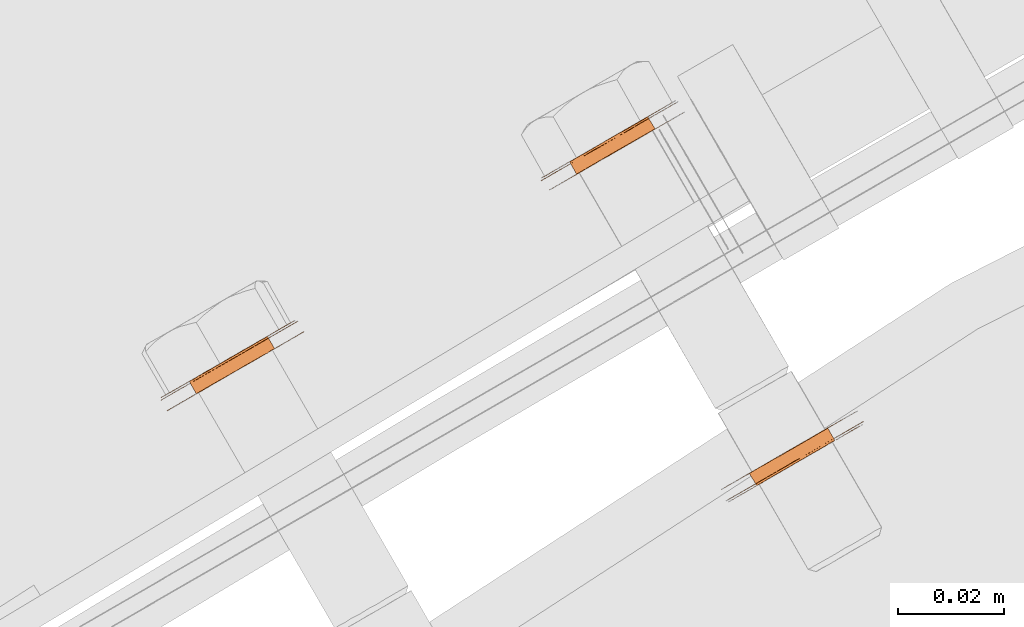
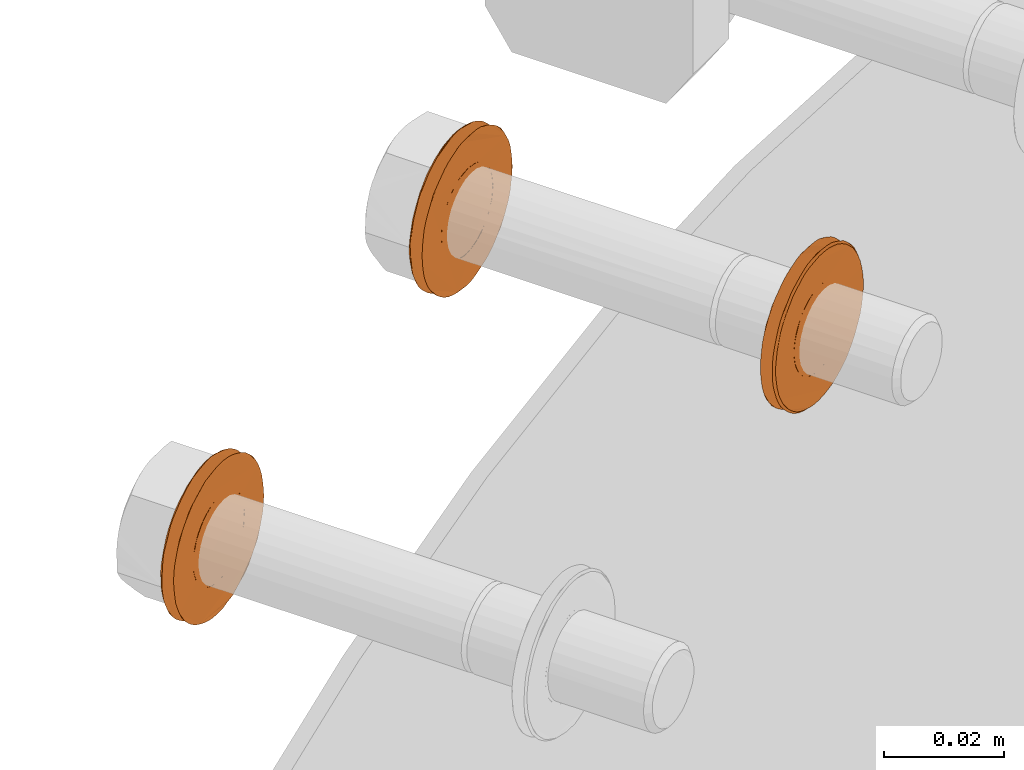
# One storey, part 109 of 126: 3 proxies.
"""IFC2X3 building model written with IfcOpenShell, lengths in millimetres."""

from ifc_helpers import new_model, si_unit, origin, origin_with_axes, place, context, project, spatial, faceted_brep, material, element, save


model = new_model("IFC2X3")

# Units and contexts
context_of_model_1 = context(None, 3, precision=0.1, world=origin())
context_of_model_2 = context(None, 3, precision=0.1, world=origin())
ifc_project = project(units=[si_unit("LENGTHUNIT", "METRE", prefix="MILLI"), si_unit("AREAUNIT", "SQUARE_METRE", prefix="CENTI"), si_unit("VOLUMEUNIT", "CUBIC_METRE", prefix="CENTI"), si_unit("MASSUNIT", "GRAM", prefix="KILO")], contexts=[context_of_model_1, context_of_model_2])

# Site, building, storey
site_placement = place(None, origin_with_axes())
site = spatial("IfcSite", under=ifc_project, at=site_placement, CompositionType="ELEMENT")
building_placement = place(site_placement, origin_with_axes())
building = spatial("IfcBuilding", under=site, at=building_placement, CompositionType="ELEMENT")
storey_placement = place(building_placement, origin_with_axes())
storey = spatial("IfcBuildingStorey", under=building, at=storey_placement, CompositionType="ELEMENT")

# Proxies
ifc_material = material(Name="STAHL")
proxy_1_placement = place(storey_placement, origin_with_axes())
element("IfcBuildingElementProxy", 1, at=proxy_1_placement, inside=storey, material=ifc_material, Name="profile", context=context_of_model_2, shape_type="Brep", body=[
    faceted_brep([(3880.0, 14908.0, 1300.0), (3881.3, 14905.7, 1300.0), (3882.2, 14906.2, 1300.6), (3880.9, 14908.5, 1300.6), (3879.0, 14907.5, 1299.5), (3880.3, 14905.1, 1299.5), (3878.0, 14906.9, 1299.1), (3879.3, 14904.5, 1299.1), (3876.2, 14905.8, 1316.0), (3877.5, 14903.5, 1316.0), (3876.5, 14902.9, 1315.8), (3875.1, 14905.2, 1315.8), (3877.2, 14906.4, 1316.0), (3878.6, 14904.1, 1316.0), (3878.2, 14907.0, 1315.8), (3879.6, 14904.7, 1315.8), (3879.2, 14907.6, 1315.4), (3880.6, 14905.3, 1315.4), (3880.2, 14908.1, 1314.9), (3881.5, 14905.8, 1314.9), (3881.1, 14908.6, 1314.2), (3882.4, 14906.3, 1314.2), (3881.8, 14909.1, 1313.4), (3883.2, 14906.8, 1313.4), (3882.5, 14909.5, 1312.5), (3883.9, 14907.1, 1312.5), (3883.1, 14909.8, 1311.4), (3884.4, 14907.5, 1311.4), (3883.5, 14910.0, 1310.3), (3884.8, 14907.7, 1310.3), (3883.8, 14910.2, 1309.1), (3885.1, 14907.9, 1309.1), (3883.9, 14910.3, 1307.9), (3885.3, 14907.9, 1307.9), (3883.9, 14910.3, 1306.7), (3885.2, 14907.9, 1306.7), (3883.7, 14910.2, 1305.5), (3885.1, 14907.8, 1305.5), (3883.4, 14910.0, 1304.4), (3884.8, 14907.7, 1304.4), (3882.9, 14909.7, 1303.3), (3884.3, 14907.4, 1303.3), (3882.4, 14909.4, 1302.3), (3883.7, 14907.1, 1302.3), (3881.7, 14909.0, 1301.4), (3883.0, 14906.7, 1301.4), (3864.9, 14896.2, 1307.7), (3865.0, 14896.3, 1309.2), (3865.2, 14896.4, 1310.8), (3865.6, 14896.6, 1312.3), (3866.1, 14896.9, 1313.8), (3866.7, 14897.3, 1315.2), (3867.5, 14897.7, 1316.5), (3868.4, 14898.2, 1317.7), (3869.3, 14898.8, 1318.8), (3870.4, 14899.4, 1319.7), (3871.6, 14900.0, 1320.6), (3872.8, 14900.7, 1321.3), (3874.0, 14901.5, 1321.8), (3875.4, 14902.2, 1322.2), (3876.7, 14903.0, 1322.4), (3878.1, 14903.8, 1322.5), (3879.4, 14904.6, 1322.4), (3880.8, 14905.4, 1322.1), (3882.1, 14906.1, 1321.7), (3883.3, 14906.8, 1321.1), (3884.5, 14907.5, 1320.4), (3885.7, 14908.2, 1319.5), (3886.7, 14908.8, 1318.5), (3887.7, 14909.3, 1317.4), (3888.5, 14909.8, 1316.1), (3889.2, 14910.2, 1314.8), (3889.8, 14910.6, 1313.4), (3890.3, 14910.9, 1311.9), (3890.6, 14911.1, 1310.4), (3890.8, 14911.2, 1308.9), (3890.9, 14911.2, 1307.3), (3890.8, 14911.1, 1305.7), (3890.6, 14911.0, 1304.2), (3890.2, 14910.8, 1302.7), (3889.7, 14910.5, 1301.2), (3888.5, 14912.5, 1301.2), (3889.1, 14912.8, 1302.7), (3889.4, 14913.0, 1304.2), (3889.7, 14913.1, 1305.7), (3889.7, 14913.2, 1307.3), (3889.7, 14913.2, 1308.9), (3889.5, 14913.0, 1310.4), (3889.2, 14912.9, 1311.9), (3888.7, 14912.6, 1313.4), (3888.1, 14912.2, 1314.8), (3887.4, 14911.8, 1316.1), (3886.5, 14911.3, 1317.4), (3885.6, 14910.8, 1318.5), (3884.5, 14910.2, 1319.5), (3883.4, 14909.5, 1320.4), (3882.2, 14908.8, 1321.1), (3880.9, 14908.1, 1321.7), (3879.6, 14907.3, 1322.1), (3878.3, 14906.6, 1322.4), (3876.9, 14905.8, 1322.5), (3875.6, 14905.0, 1322.4), (3874.2, 14904.2, 1322.2), (3872.9, 14903.5, 1321.8), (3871.6, 14902.7, 1321.3), (3870.4, 14902.0, 1320.6), (3869.3, 14901.4, 1319.7), (3868.2, 14900.7, 1318.8), (3867.2, 14900.2, 1317.7), (3866.3, 14899.7, 1316.5), (3865.6, 14899.2, 1315.2), (3865.0, 14898.9, 1313.8), (3864.4, 14898.6, 1312.3), (3864.1, 14898.4, 1310.8), (3863.9, 14898.2, 1309.2), (3863.8, 14898.2, 1307.7), (3863.8, 14898.2, 1306.1), (3864.0, 14898.3, 1304.6), (3864.3, 14898.5, 1303.0), (3864.8, 14898.8, 1301.6), (3865.4, 14899.1, 1300.2), (3866.1, 14899.6, 1298.8), (3867.0, 14900.1, 1297.6), (3867.9, 14900.6, 1296.5), (3869.0, 14901.2, 1295.5), (3870.1, 14901.9, 1294.6), (3871.3, 14902.6, 1293.9), (3872.6, 14903.3, 1293.3), (3873.9, 14904.0, 1292.9), (3875.2, 14904.8, 1292.6), (3876.6, 14905.6, 1292.5), (3877.9, 14906.4, 1292.5), (3879.3, 14907.2, 1292.8), (3880.6, 14907.9, 1293.2), (3881.9, 14908.7, 1293.7), (3883.1, 14909.4, 1294.4), (3884.2, 14910.0, 1295.2), (3885.3, 14910.6, 1296.2), (3886.3, 14911.2, 1297.3), (3887.2, 14911.7, 1298.5), (3887.9, 14912.1, 1299.8), (3889.1, 14910.1, 1299.8), (3888.3, 14909.7, 1298.5), (3887.4, 14909.2, 1297.3), (3886.5, 14908.6, 1296.2), (3885.4, 14908.0, 1295.2), (3884.2, 14907.4, 1294.4), (3883.0, 14906.7, 1293.7), (3881.8, 14905.9, 1293.2), (3880.4, 14905.2, 1292.8), (3879.1, 14904.4, 1292.5), (3877.7, 14903.6, 1292.5), (3876.4, 14902.8, 1292.6), (3875.0, 14902.0, 1292.9), (3873.7, 14901.3, 1293.3), (3872.5, 14900.6, 1293.9), (3871.3, 14899.9, 1294.6), (3870.1, 14899.2, 1295.5), (3869.1, 14898.6, 1296.5), (3868.1, 14898.1, 1297.6), (3867.3, 14897.6, 1298.8), (3866.6, 14897.2, 1300.2), (3866.0, 14896.8, 1301.6), (3865.5, 14896.5, 1303.0), (3865.2, 14896.3, 1304.6), (3865.0, 14896.2, 1306.1), (3868.7, 14901.5, 1296.0), (3869.8, 14902.1, 1295.1), (3871.0, 14902.8, 1294.4), (3872.3, 14903.6, 1293.7), (3873.6, 14904.3, 1293.3), (3874.9, 14905.1, 1293.0), (3876.3, 14905.9, 1292.9), (3877.7, 14906.7, 1292.9), (3879.0, 14907.5, 1293.2), (3880.3, 14908.2, 1293.6), (3881.6, 14909.0, 1294.1), (3882.8, 14909.7, 1294.8), (3884.0, 14910.3, 1295.7), (3885.1, 14911.0, 1296.7), (3886.0, 14911.5, 1297.8), (3886.9, 14912.0, 1299.0), (3887.6, 14912.4, 1300.4), (3888.2, 14912.8, 1301.8), (3888.7, 14913.0, 1303.3), (3889.0, 14913.2, 1304.8), (3889.2, 14913.3, 1306.4), (3889.2, 14913.3, 1308.0), (3889.1, 14913.3, 1309.6), (3888.8, 14913.1, 1311.1), (3888.4, 14912.9, 1312.6), (3887.8, 14912.6, 1314.1), (3887.2, 14912.2, 1315.4), (3886.4, 14911.7, 1316.7), (3885.4, 14911.2, 1317.9), (3884.4, 14910.6, 1318.9), (3883.3, 14909.9, 1319.8), (3882.1, 14909.2, 1320.6), (3880.8, 14908.5, 1321.2), (3879.5, 14907.8, 1321.7), (3878.2, 14907.0, 1322.0), (3876.8, 14906.2, 1322.1), (3875.4, 14905.4, 1322.0), (3874.1, 14904.6, 1321.8), (3872.8, 14903.8, 1321.4), (3871.5, 14903.1, 1320.9), (3870.3, 14902.4, 1320.1), (3869.1, 14901.7, 1319.3), (3868.0, 14901.1, 1318.3), (3867.1, 14900.6, 1317.2), (3866.2, 14900.1, 1315.9), (3865.5, 14899.7, 1314.6), (3864.9, 14899.3, 1313.2), (3864.4, 14899.0, 1311.7), (3864.1, 14898.9, 1310.1), (3863.9, 14898.8, 1308.6), (3863.9, 14898.7, 1307.0), (3864.0, 14898.8, 1305.4), (3864.3, 14899.0, 1303.9), (3864.7, 14899.2, 1302.4), (3865.3, 14899.5, 1300.9), (3865.9, 14899.9, 1299.5), (3866.7, 14900.4, 1298.3), (3867.7, 14900.9, 1297.1), (3872.0, 14903.4, 1300.8), (3872.9, 14903.9, 1300.1), (3873.9, 14904.5, 1299.6), (3874.9, 14905.1, 1299.2), (3875.9, 14905.7, 1299.0), (3876.9, 14906.3, 1299.0), (3874.1, 14904.6, 1315.5), (3873.1, 14904.1, 1315.0), (3872.2, 14903.6, 1314.4), (3871.4, 14903.1, 1313.6), (3870.7, 14902.7, 1312.7), (3870.2, 14902.3, 1311.7), (3869.7, 14902.1, 1310.6), (3869.4, 14901.9, 1309.4), (3869.2, 14901.8, 1308.2), (3869.2, 14901.8, 1307.0), (3869.3, 14901.9, 1305.8), (3869.6, 14902.0, 1304.7), (3870.0, 14902.3, 1303.5), (3870.6, 14902.6, 1302.5), (3871.3, 14903.0, 1301.6), (3873.6, 14901.2, 1314.4), (3872.8, 14900.7, 1313.6), (3874.5, 14901.7, 1315.0), (3875.5, 14902.3, 1315.5), (3878.3, 14903.9, 1299.0), (3877.2, 14903.3, 1299.0), (3876.2, 14902.7, 1299.2), (3875.2, 14902.1, 1299.6), (3874.3, 14901.6, 1300.1), (3873.4, 14901.1, 1300.8), (3872.6, 14900.6, 1301.6), (3871.9, 14900.3, 1302.5), (3871.4, 14899.9, 1303.5), (3871.0, 14899.7, 1304.7), (3870.7, 14899.5, 1305.8), (3870.5, 14899.5, 1307.0), (3870.6, 14899.5, 1308.2), (3870.7, 14899.6, 1309.4), (3871.1, 14899.7, 1310.6), (3871.5, 14900.0, 1311.7), (3872.1, 14900.3, 1312.7)], [[[0, 1, 2, 3]], [[4, 5, 1, 0]], [[4, 6, 7, 5]], [[8, 9, 10, 11]], [[12, 13, 9, 8]], [[14, 15, 13, 12]], [[16, 17, 15, 14]], [[18, 19, 17, 16]], [[20, 21, 19, 18]], [[22, 23, 21, 20]], [[24, 25, 23, 22]], [[26, 27, 25, 24]], [[28, 29, 27, 26]], [[30, 31, 29, 28]], [[32, 33, 31, 30]], [[34, 35, 33, 32]], [[36, 37, 35, 34]], [[38, 39, 37, 36]], [[40, 41, 39, 38]], [[42, 43, 41, 40]], [[44, 45, 43, 42]], [[3, 2, 45, 44]], [[46, 47, 48, 49, 50, 51, 52, 53, 54, 55, 56, 57, 58, 59, 60, 61, 62, 63, 64, 65, 66, 67, 68, 69, 70, 71, 72, 73, 74, 75, 76, 77, 78, 79, 80, 81, 82, 83, 84, 85, 86, 87, 88, 89, 90, 91, 92, 93, 94, 95, 96, 97, 98, 99, 100, 101, 102, 103, 104, 105, 106, 107, 108, 109, 110, 111, 112, 113, 114, 115, 116, 117, 118, 119, 120, 121, 122, 123, 124, 125, 126, 127, 128, 129, 130, 131, 132, 133, 134, 135, 136, 137, 138, 139, 140, 81, 80, 141, 142, 143, 144, 145, 146, 147, 148, 149, 150, 151, 152, 153, 154, 155, 156, 157, 158, 159, 160, 161, 162, 163, 164, 165]], [[115, 114, 113, 112, 111, 110, 109, 108, 107, 106, 105, 104, 103, 102, 101, 100, 99, 98, 97, 96, 95, 94, 93, 92, 91, 90, 89, 88, 87, 86, 85, 84, 83, 82, 81, 140, 139, 138, 137, 136, 135, 134, 133, 132, 131, 130, 129, 128, 127, 126, 125, 124, 166, 167, 168, 169, 170, 171, 172, 173, 174, 175, 176, 177, 178, 179, 180, 181, 182, 183, 184, 185, 186, 187, 188, 189, 190, 191, 192, 193, 194, 195, 196, 197, 198, 199, 200, 201, 202, 203, 204, 205, 206, 207, 208, 209, 210, 211, 212, 213, 214, 215, 216, 217, 218, 219, 220, 221, 222, 223, 166, 124, 123, 122, 121, 120, 119, 118, 117, 116]], [[216, 215, 214, 213, 212, 211, 210, 209, 208, 207, 206, 205, 204, 203, 202, 201, 200, 199, 198, 197, 196, 195, 194, 193, 192, 191, 190, 189, 188, 187, 186, 185, 184, 183, 182, 181, 180, 179, 178, 177, 176, 175, 174, 173, 172, 171, 170, 169, 168, 167, 166, 223, 224, 225, 226, 227, 228, 229, 6, 4, 0, 3, 44, 42, 40, 38, 36, 34, 32, 30, 28, 26, 24, 22, 20, 18, 16, 14, 12, 8, 11, 230, 231, 232, 233, 234, 235, 236, 237, 238, 239, 240, 241, 242, 243, 244, 224, 223, 222, 221, 220, 219, 218, 217]], [[232, 245, 246, 233]], [[231, 247, 245, 232]], [[230, 248, 247, 231]], [[229, 249, 7, 6]], [[11, 10, 248, 230]], [[228, 250, 249, 229]], [[227, 251, 250, 228]], [[226, 252, 251, 227]], [[225, 253, 252, 226]], [[224, 254, 253, 225]], [[244, 255, 254, 224]], [[243, 256, 255, 244]], [[242, 257, 256, 243]], [[241, 258, 257, 242]], [[240, 259, 258, 241]], [[239, 260, 259, 240]], [[238, 261, 260, 239]], [[237, 262, 261, 238]], [[236, 263, 262, 237]], [[235, 264, 263, 236]], [[234, 265, 264, 235]], [[233, 246, 265, 234]], [[46, 165, 164, 163, 162, 161, 160, 159, 158, 157, 156, 254, 255, 256, 257, 258, 259, 260, 261, 262, 263, 264, 265, 246, 245, 247, 248, 10, 9, 13, 15, 17, 19, 21, 23, 25, 27, 29, 31, 33, 35, 37, 39, 41, 43, 45, 2, 1, 5, 7, 249, 250, 251, 252, 253, 254, 156, 155, 154, 153, 152, 151, 150, 149, 148, 147, 146, 145, 144, 143, 142, 141, 80, 79, 78, 77, 76, 75, 74, 73, 72, 71, 70, 69, 68, 67, 66, 65, 64, 63, 62, 61, 60, 59, 58, 57, 56, 55, 54, 53, 52, 51, 50, 49, 48, 47]]]),
])
proxy_2_placement = place(storey_placement, origin_with_axes())
element("IfcBuildingElementProxy", 2, at=proxy_2_placement, inside=storey, material=ifc_material, Name="profile", context=context_of_model_2, shape_type="Brep", body=[
    faceted_brep([(3980.3, 14884.6, 1316.2), (3978.9, 14887.0, 1316.2), (3978.0, 14886.4, 1316.8), (3979.4, 14884.1, 1316.8), (3981.3, 14885.2, 1315.8), (3979.9, 14887.5, 1315.8), (3982.3, 14885.8, 1315.5), (3981.0, 14888.1, 1315.5), (3982.3, 14885.8, 1332.3), (3981.0, 14888.1, 1332.3), (3982.0, 14888.7, 1332.4), (3983.3, 14886.4, 1332.4), (3983.3, 14886.4, 1315.4), (3982.0, 14888.7, 1315.4), (3981.3, 14885.2, 1332.1), (3979.9, 14887.5, 1332.1), (3980.3, 14884.6, 1331.7), (3978.9, 14887.0, 1331.7), (3979.4, 14884.1, 1331.1), (3978.0, 14886.4, 1331.1), (3978.5, 14883.6, 1330.4), (3977.2, 14886.0, 1330.4), (3977.8, 14883.2, 1329.5), (3976.4, 14885.5, 1329.5), (3977.2, 14882.8, 1328.5), (3975.8, 14885.2, 1328.5), (3976.7, 14882.5, 1327.5), (3975.3, 14884.9, 1327.5), (3976.3, 14882.3, 1326.3), (3974.9, 14884.7, 1326.3), (3976.1, 14882.2, 1325.1), (3974.7, 14884.5, 1325.1), (3976.0, 14882.2, 1323.9), (3974.6, 14884.5, 1323.9), (3976.1, 14882.2, 1322.7), (3974.7, 14884.5, 1322.7), (3976.3, 14882.3, 1321.5), (3974.9, 14884.7, 1321.5), (3976.7, 14882.5, 1320.4), (3975.3, 14884.9, 1320.4), (3977.2, 14882.8, 1319.3), (3975.8, 14885.2, 1319.3), (3977.8, 14883.2, 1318.4), (3976.4, 14885.5, 1318.4), (3978.5, 14883.6, 1317.5), (3977.2, 14886.0, 1317.5), (3970.2, 14879.3, 1323.9), (3970.2, 14879.3, 1325.5), (3970.4, 14879.4, 1327.0), (3970.8, 14879.6, 1328.6), (3971.3, 14879.9, 1330.0), (3971.9, 14880.3, 1331.4), (3972.6, 14880.7, 1332.7), (3973.5, 14881.2, 1334.0), (3974.5, 14881.7, 1335.1), (3975.5, 14882.3, 1336.1), (3976.7, 14883.0, 1336.9), (3977.9, 14883.7, 1337.6), (3979.1, 14884.4, 1338.2), (3980.4, 14885.2, 1338.6), (3981.8, 14886.0, 1338.8), (3983.1, 14886.8, 1338.9), (3984.5, 14887.5, 1338.8), (3985.9, 14888.3, 1338.6), (3987.2, 14889.1, 1338.2), (3988.4, 14889.8, 1337.6), (3989.6, 14890.5, 1336.9), (3990.8, 14891.2, 1336.1), (3991.8, 14891.8, 1335.1), (3992.8, 14892.3, 1334.0), (3993.7, 14892.8, 1332.7), (3994.4, 14893.3, 1331.4), (3995.0, 14893.6, 1330.0), (3995.5, 14893.9, 1328.6), (3995.9, 14894.1, 1327.0), (3996.1, 14894.2, 1325.5), (3996.1, 14894.3, 1323.9), (3996.1, 14894.2, 1322.4), (3995.9, 14894.1, 1320.8), (3995.5, 14893.9, 1319.3), (3995.0, 14893.6, 1317.8), (3994.4, 14893.3, 1316.4), (3993.7, 14892.8, 1315.1), (3992.8, 14892.3, 1313.9), (3991.8, 14891.8, 1312.8), (3990.8, 14891.2, 1311.8), (3989.6, 14890.5, 1310.9), (3988.4, 14889.8, 1310.2), (3987.2, 14889.1, 1309.7), (3985.9, 14888.3, 1309.3), (3984.5, 14887.5, 1309.0), (3983.1, 14886.8, 1308.9), (3981.8, 14886.0, 1309.0), (3980.4, 14885.2, 1309.3), (3979.1, 14884.4, 1309.7), (3977.9, 14883.7, 1310.2), (3976.7, 14883.0, 1310.9), (3975.5, 14882.3, 1311.8), (3974.5, 14881.7, 1312.8), (3973.5, 14881.2, 1313.9), (3972.6, 14880.7, 1315.1), (3971.5, 14882.7, 1315.1), (3972.3, 14883.2, 1313.9), (3973.3, 14883.7, 1312.8), (3974.4, 14884.3, 1311.8), (3975.5, 14885.0, 1310.9), (3976.7, 14885.7, 1310.2), (3978.0, 14886.4, 1309.7), (3979.3, 14887.2, 1309.3), (3980.6, 14888.0, 1309.0), (3982.0, 14888.7, 1308.9), (3983.4, 14889.5, 1309.0), (3984.7, 14890.3, 1309.3), (3986.0, 14891.1, 1309.7), (3987.3, 14891.8, 1310.2), (3988.5, 14892.5, 1310.9), (3989.6, 14893.2, 1311.8), (3990.7, 14893.8, 1312.8), (3991.7, 14894.3, 1313.9), (3992.5, 14894.8, 1315.1), (3993.2, 14895.2, 1316.4), (3993.9, 14895.6, 1317.8), (3994.4, 14895.9, 1319.3), (3994.7, 14896.1, 1320.8), (3994.9, 14896.2, 1322.4), (3995.0, 14896.2, 1323.9), (3994.9, 14896.2, 1325.5), (3994.7, 14896.1, 1327.0), (3994.4, 14895.9, 1328.6), (3993.9, 14895.6, 1330.0), (3993.2, 14895.2, 1331.4), (3992.5, 14894.8, 1332.7), (3991.7, 14894.3, 1334.0), (3990.7, 14893.8, 1335.1), (3989.6, 14893.2, 1336.1), (3988.5, 14892.5, 1336.9), (3987.3, 14891.8, 1337.6), (3986.0, 14891.1, 1338.2), (3984.7, 14890.3, 1338.6), (3983.4, 14889.5, 1338.8), (3982.0, 14888.7, 1338.9), (3980.6, 14888.0, 1338.8), (3979.3, 14887.2, 1338.6), (3978.0, 14886.4, 1338.2), (3976.7, 14885.7, 1337.6), (3975.5, 14885.0, 1336.9), (3974.4, 14884.3, 1336.1), (3973.3, 14883.7, 1335.1), (3972.3, 14883.2, 1334.0), (3971.5, 14882.7, 1332.7), (3970.7, 14882.3, 1331.4), (3970.1, 14881.9, 1330.0), (3969.6, 14881.6, 1328.6), (3969.3, 14881.4, 1327.0), (3969.1, 14881.3, 1325.5), (3969.0, 14881.2, 1323.9), (3969.1, 14881.3, 1322.4), (3969.3, 14881.4, 1320.8), (3969.6, 14881.6, 1319.3), (3970.1, 14881.9, 1317.8), (3970.7, 14882.3, 1316.4), (3971.9, 14880.3, 1316.4), (3971.3, 14879.9, 1317.8), (3970.8, 14879.6, 1319.3), (3970.4, 14879.4, 1320.8), (3970.2, 14879.3, 1322.4), (3970.7, 14879.1, 1323.1), (3970.7, 14879.1, 1324.7), (3970.9, 14879.2, 1326.3), (3971.2, 14879.4, 1327.8), (3971.6, 14879.6, 1329.3), (3972.2, 14880.0, 1330.8), (3972.9, 14880.4, 1332.1), (3973.7, 14880.8, 1333.4), (3974.7, 14881.4, 1334.5), (3975.7, 14882.0, 1335.6), (3976.8, 14882.6, 1336.4), (3978.0, 14883.3, 1337.2), (3979.3, 14884.1, 1337.8), (3980.6, 14884.8, 1338.2), (3982.0, 14885.6, 1338.4), (3983.3, 14886.4, 1338.5), (3984.7, 14887.2, 1338.4), (3986.1, 14888.0, 1338.2), (3987.4, 14888.7, 1337.8), (3988.7, 14889.5, 1337.2), (3989.9, 14890.2, 1336.4), (3991.0, 14890.8, 1335.6), (3992.0, 14891.4, 1334.5), (3993.0, 14892.0, 1333.4), (3993.8, 14892.5, 1332.1), (3994.5, 14892.9, 1330.8), (3995.1, 14893.2, 1329.3), (3995.5, 14893.4, 1327.8), (3995.8, 14893.6, 1326.3), (3996.0, 14893.7, 1324.7), (3996.0, 14893.7, 1323.1), (3995.8, 14893.6, 1321.6), (3995.5, 14893.4, 1320.0), (3995.1, 14893.2, 1318.5), (3994.5, 14892.9, 1317.1), (3993.8, 14892.5, 1315.7), (3993.0, 14892.0, 1314.5), (3992.0, 14891.4, 1313.3), (3991.0, 14890.8, 1312.3), (3989.9, 14890.2, 1311.4), (3988.7, 14889.5, 1310.7), (3987.4, 14888.7, 1310.1), (3986.1, 14888.0, 1309.7), (3984.7, 14887.2, 1309.4), (3983.3, 14886.4, 1309.3), (3982.0, 14885.6, 1309.4), (3980.6, 14884.8, 1309.7), (3979.3, 14884.1, 1310.1), (3978.0, 14883.3, 1310.7), (3976.8, 14882.6, 1311.4), (3975.7, 14882.0, 1312.3), (3974.7, 14881.4, 1313.3), (3973.7, 14880.8, 1314.5), (3972.9, 14880.4, 1315.7), (3972.2, 14880.0, 1317.1), (3971.6, 14879.6, 1318.5), (3971.2, 14879.4, 1320.0), (3970.9, 14879.2, 1321.6), (3988.2, 14889.2, 1317.5), (3987.3, 14888.7, 1316.8), (3986.4, 14888.2, 1316.2), (3985.4, 14887.6, 1315.8), (3984.4, 14887.0, 1315.5), (3984.4, 14887.0, 1332.3), (3985.4, 14887.6, 1332.1), (3986.4, 14888.2, 1331.7), (3987.3, 14888.7, 1331.1), (3988.2, 14889.2, 1330.4), (3988.9, 14889.6, 1329.5), (3989.5, 14890.0, 1328.5), (3990.0, 14890.3, 1327.5), (3990.4, 14890.5, 1326.3), (3990.6, 14890.6, 1325.1), (3990.7, 14890.7, 1323.9), (3990.6, 14890.6, 1322.7), (3990.4, 14890.5, 1321.5), (3990.0, 14890.3, 1320.4), (3989.5, 14890.0, 1319.3), (3988.9, 14889.6, 1318.4), (3983.0, 14889.4, 1332.3), (3983.0, 14889.4, 1315.5), (3984.1, 14889.9, 1315.8), (3985.1, 14890.5, 1316.2), (3986.0, 14891.0, 1316.8), (3986.8, 14891.5, 1317.5), (3987.6, 14892.0, 1318.4), (3988.2, 14892.3, 1319.3), (3988.7, 14892.6, 1320.4), (3989.1, 14892.8, 1321.5), (3989.3, 14893.0, 1322.7), (3989.4, 14893.0, 1323.9), (3989.3, 14893.0, 1325.1), (3989.1, 14892.8, 1326.3), (3988.7, 14892.6, 1327.5), (3988.2, 14892.3, 1328.5), (3987.6, 14892.0, 1329.5), (3986.8, 14891.5, 1330.4), (3986.0, 14891.0, 1331.1), (3985.1, 14890.5, 1331.7), (3984.1, 14889.9, 1332.1)], [[[0, 1, 2, 3]], [[4, 5, 1, 0]], [[6, 7, 5, 4]], [[8, 9, 10, 11]], [[12, 13, 7, 6]], [[14, 15, 9, 8]], [[16, 17, 15, 14]], [[18, 19, 17, 16]], [[20, 21, 19, 18]], [[22, 23, 21, 20]], [[24, 25, 23, 22]], [[26, 27, 25, 24]], [[28, 29, 27, 26]], [[30, 31, 29, 28]], [[32, 33, 31, 30]], [[34, 35, 33, 32]], [[36, 37, 35, 34]], [[38, 39, 37, 36]], [[40, 41, 39, 38]], [[42, 43, 41, 40]], [[44, 45, 43, 42]], [[3, 2, 45, 44]], [[46, 47, 48, 49, 50, 51, 52, 53, 54, 55, 56, 57, 58, 59, 60, 61, 62, 63, 64, 65, 66, 67, 68, 69, 70, 71, 72, 73, 74, 75, 76, 77, 78, 79, 80, 81, 82, 83, 84, 85, 86, 87, 88, 89, 90, 91, 92, 93, 94, 95, 96, 97, 98, 99, 100, 101, 102, 103, 104, 105, 106, 107, 108, 109, 110, 111, 112, 113, 114, 115, 116, 117, 118, 119, 120, 121, 122, 123, 124, 125, 126, 127, 128, 129, 130, 131, 132, 133, 134, 135, 136, 137, 138, 139, 140, 141, 142, 143, 144, 145, 146, 147, 148, 149, 150, 151, 152, 153, 154, 155, 156, 157, 158, 159, 160, 101, 100, 161, 162, 163, 164, 165]], [[166, 167, 168, 169, 170, 171, 172, 173, 174, 175, 176, 177, 178, 179, 180, 181, 182, 183, 184, 185, 186, 187, 188, 189, 190, 191, 192, 193, 194, 195, 196, 197, 198, 199, 200, 201, 202, 83, 82, 81, 80, 79, 78, 77, 76, 75, 74, 73, 72, 71, 70, 69, 68, 67, 66, 65, 64, 63, 62, 61, 60, 59, 58, 57, 56, 55, 54, 53, 52, 51, 50, 49, 48, 47, 46, 165, 164, 163, 162, 161, 100, 99, 98, 97, 96, 95, 94, 93, 92, 91, 90, 89, 88, 87, 86, 85, 84, 83, 202, 203, 204, 205, 206, 207, 208, 209, 210, 211, 212, 213, 214, 215, 216, 217, 218, 219, 220, 221, 222, 223]], [[167, 166, 223, 222, 221, 220, 219, 218, 217, 216, 215, 214, 213, 212, 211, 210, 209, 208, 207, 206, 205, 204, 203, 224, 225, 226, 227, 228, 12, 6, 4, 0, 3, 44, 42, 40, 38, 36, 34, 32, 30, 28, 26, 24, 22, 20, 18, 16, 14, 8, 11, 229, 230, 231, 232, 233, 234, 235, 236, 237, 238, 239, 240, 241, 242, 243, 244, 224, 203, 202, 201, 200, 199, 198, 197, 196, 195, 194, 193, 192, 191, 190, 189, 188, 187, 186, 185, 184, 183, 182, 181, 180, 179, 178, 177, 176, 175, 174, 173, 172, 171, 170, 169, 168]], [[229, 11, 10, 245]], [[12, 228, 246, 13]], [[228, 227, 247, 246]], [[227, 226, 248, 247]], [[226, 225, 249, 248]], [[225, 224, 250, 249]], [[224, 244, 251, 250]], [[244, 243, 252, 251]], [[243, 242, 253, 252]], [[242, 241, 254, 253]], [[241, 240, 255, 254]], [[240, 239, 256, 255]], [[239, 238, 257, 256]], [[238, 237, 258, 257]], [[237, 236, 259, 258]], [[236, 235, 260, 259]], [[235, 234, 261, 260]], [[234, 233, 262, 261]], [[233, 232, 263, 262]], [[232, 231, 264, 263]], [[231, 230, 265, 264]], [[230, 229, 245, 265]], [[155, 154, 153, 152, 151, 150, 149, 148, 147, 146, 145, 144, 143, 142, 141, 140, 139, 138, 137, 136, 135, 134, 133, 132, 131, 130, 129, 128, 127, 126, 125, 124, 123, 122, 121, 120, 119, 118, 117, 251, 252, 253, 254, 255, 256, 257, 258, 259, 260, 261, 262, 263, 264, 265, 245, 10, 9, 15, 17, 19, 21, 23, 25, 27, 29, 31, 33, 35, 37, 39, 41, 43, 45, 2, 1, 5, 7, 13, 246, 247, 248, 249, 250, 251, 117, 116, 115, 114, 113, 112, 111, 110, 109, 108, 107, 106, 105, 104, 103, 102, 101, 160, 159, 158, 157, 156]]]),
])
proxy_3_placement = place(storey_placement, origin_with_axes())
element("IfcBuildingElementProxy", 3, at=proxy_3_placement, inside=storey, material=ifc_material, Name="profile", context=context_of_model_2, shape_type="Brep", body=[
    faceted_brep([(3951.2, 14949.1, 1316.2), (3952.6, 14946.8, 1316.2), (3953.5, 14947.3, 1316.8), (3952.1, 14949.7, 1316.8), (3950.2, 14948.6, 1315.8), (3951.6, 14946.2, 1315.8), (3949.2, 14948.0, 1315.5), (3950.5, 14945.6, 1315.5), (3949.2, 14948.0, 1332.3), (3950.5, 14945.6, 1332.3), (3949.5, 14945.0, 1332.4), (3948.1, 14947.4, 1332.4), (3948.1, 14947.4, 1315.4), (3949.5, 14945.0, 1315.4), (3950.2, 14948.6, 1332.1), (3951.6, 14946.2, 1332.1), (3951.2, 14949.1, 1331.7), (3952.6, 14946.8, 1331.7), (3952.1, 14949.7, 1331.1), (3953.5, 14947.3, 1331.1), (3953.0, 14950.2, 1330.4), (3954.3, 14947.8, 1330.4), (3953.7, 14950.6, 1329.5), (3955.1, 14948.3, 1329.5), (3954.3, 14951.0, 1328.5), (3955.7, 14948.6, 1328.5), (3954.8, 14951.2, 1327.5), (3956.2, 14948.9, 1327.5), (3955.2, 14951.5, 1326.3), (3956.6, 14949.1, 1326.3), (3955.4, 14951.6, 1325.1), (3956.8, 14949.2, 1325.1), (3955.5, 14951.6, 1323.9), (3956.9, 14949.3, 1323.9), (3955.4, 14951.6, 1322.7), (3956.8, 14949.2, 1322.7), (3955.2, 14951.5, 1321.5), (3956.6, 14949.1, 1321.5), (3954.8, 14951.2, 1320.4), (3956.2, 14948.9, 1320.4), (3954.3, 14951.0, 1319.3), (3955.7, 14948.6, 1319.3), (3953.7, 14950.6, 1318.4), (3955.1, 14948.3, 1318.4), (3953.0, 14950.2, 1317.5), (3954.3, 14947.8, 1317.5), (3936.5, 14937.5, 1323.9), (3936.6, 14937.6, 1325.5), (3936.8, 14937.7, 1327.0), (3937.1, 14937.9, 1328.6), (3937.6, 14938.2, 1330.0), (3938.2, 14938.5, 1331.4), (3939.0, 14939.0, 1332.7), (3939.8, 14939.5, 1334.0), (3940.8, 14940.0, 1335.1), (3941.9, 14940.6, 1336.1), (3943.0, 14941.3, 1336.9), (3944.2, 14942.0, 1337.6), (3945.5, 14942.7, 1338.2), (3946.8, 14943.5, 1338.6), (3948.1, 14944.3, 1338.8), (3949.5, 14945.0, 1338.9), (3950.9, 14945.8, 1338.8), (3952.2, 14946.6, 1338.6), (3953.5, 14947.4, 1338.2), (3954.8, 14948.1, 1337.6), (3956.0, 14948.8, 1336.9), (3957.1, 14949.4, 1336.1), (3958.2, 14950.1, 1335.1), (3959.2, 14950.6, 1334.0), (3960.0, 14951.1, 1332.7), (3960.7, 14951.5, 1331.4), (3961.4, 14951.9, 1330.0), (3961.9, 14952.2, 1328.6), (3962.2, 14952.4, 1327.0), (3962.4, 14952.5, 1325.5), (3962.5, 14952.5, 1323.9), (3962.4, 14952.5, 1322.4), (3962.2, 14952.4, 1320.8), (3961.9, 14952.2, 1319.3), (3961.4, 14951.9, 1317.8), (3960.7, 14951.5, 1316.4), (3960.0, 14951.1, 1315.1), (3958.9, 14953.1, 1315.1), (3959.6, 14953.5, 1316.4), (3960.2, 14953.9, 1317.8), (3960.7, 14954.2, 1319.3), (3961.1, 14954.4, 1320.8), (3961.3, 14954.5, 1322.4), (3961.3, 14954.5, 1323.9), (3961.3, 14954.5, 1325.5), (3961.1, 14954.4, 1327.0), (3960.7, 14954.2, 1328.6), (3960.2, 14953.9, 1330.0), (3959.6, 14953.5, 1331.4), (3958.9, 14953.1, 1332.7), (3958.0, 14952.6, 1334.0), (3957.0, 14952.0, 1335.1), (3956.0, 14951.4, 1336.1), (3954.8, 14950.8, 1336.9), (3953.6, 14950.1, 1337.6), (3952.4, 14949.3, 1338.2), (3951.1, 14948.6, 1338.6), (3949.7, 14947.8, 1338.8), (3948.3, 14947.0, 1338.9), (3947.0, 14946.2, 1338.8), (3945.6, 14945.5, 1338.6), (3944.3, 14944.7, 1338.2), (3943.1, 14944.0, 1337.6), (3941.9, 14943.3, 1336.9), (3940.7, 14942.6, 1336.1), (3939.7, 14942.0, 1335.1), (3938.7, 14941.5, 1334.0), (3937.8, 14941.0, 1332.7), (3937.1, 14940.5, 1331.4), (3936.5, 14940.2, 1330.0), (3936.0, 14939.9, 1328.6), (3935.6, 14939.7, 1327.0), (3935.4, 14939.6, 1325.5), (3935.4, 14939.5, 1323.9), (3935.4, 14939.6, 1322.4), (3935.6, 14939.7, 1320.8), (3936.0, 14939.9, 1319.3), (3936.5, 14940.2, 1317.8), (3937.1, 14940.5, 1316.4), (3937.8, 14941.0, 1315.1), (3938.7, 14941.5, 1313.9), (3939.7, 14942.0, 1312.8), (3940.7, 14942.6, 1311.8), (3941.9, 14943.3, 1310.9), (3943.1, 14944.0, 1310.2), (3944.3, 14944.7, 1309.7), (3945.6, 14945.5, 1309.3), (3947.0, 14946.2, 1309.0), (3948.3, 14947.0, 1308.9), (3949.7, 14947.8, 1309.0), (3951.1, 14948.6, 1309.3), (3952.4, 14949.3, 1309.7), (3953.6, 14950.1, 1310.2), (3954.8, 14950.8, 1310.9), (3956.0, 14951.4, 1311.8), (3957.0, 14952.0, 1312.8), (3958.0, 14952.6, 1313.9), (3959.2, 14950.6, 1313.9), (3958.2, 14950.1, 1312.8), (3957.1, 14949.4, 1311.8), (3956.0, 14948.8, 1310.9), (3954.8, 14948.1, 1310.2), (3953.5, 14947.4, 1309.7), (3952.2, 14946.6, 1309.3), (3950.9, 14945.8, 1309.0), (3949.5, 14945.0, 1308.9), (3948.1, 14944.3, 1309.0), (3946.8, 14943.5, 1309.3), (3945.5, 14942.7, 1309.7), (3944.2, 14942.0, 1310.2), (3943.0, 14941.3, 1310.9), (3941.9, 14940.6, 1311.8), (3940.8, 14940.0, 1312.8), (3939.8, 14939.5, 1313.9), (3939.0, 14939.0, 1315.1), (3938.2, 14938.5, 1316.4), (3937.6, 14938.2, 1317.8), (3937.1, 14937.9, 1319.3), (3936.8, 14937.7, 1320.8), (3936.6, 14937.6, 1322.4), (3938.5, 14941.8, 1314.5), (3939.5, 14942.4, 1313.3), (3940.5, 14943.0, 1312.3), (3941.6, 14943.6, 1311.4), (3942.8, 14944.3, 1310.7), (3944.1, 14945.0, 1310.1), (3945.4, 14945.8, 1309.7), (3946.8, 14946.6, 1309.4), (3948.1, 14947.4, 1309.3), (3949.5, 14948.2, 1309.4), (3950.9, 14948.9, 1309.7), (3952.2, 14949.7, 1310.1), (3953.5, 14950.4, 1310.7), (3954.7, 14951.1, 1311.4), (3955.8, 14951.8, 1312.3), (3956.8, 14952.4, 1313.3), (3957.8, 14952.9, 1314.5), (3958.6, 14953.4, 1315.7), (3959.3, 14953.8, 1317.1), (3959.9, 14954.2, 1318.5), (3960.3, 14954.4, 1320.0), (3960.6, 14954.6, 1321.6), (3960.8, 14954.7, 1323.1), (3960.8, 14954.7, 1324.7), (3960.6, 14954.6, 1326.3), (3960.3, 14954.4, 1327.8), (3959.9, 14954.2, 1329.3), (3959.3, 14953.8, 1330.8), (3958.6, 14953.4, 1332.1), (3957.8, 14952.9, 1333.4), (3956.8, 14952.4, 1334.5), (3955.8, 14951.8, 1335.6), (3954.7, 14951.1, 1336.4), (3953.5, 14950.4, 1337.2), (3952.2, 14949.7, 1337.8), (3950.9, 14948.9, 1338.2), (3949.5, 14948.2, 1338.4), (3948.1, 14947.4, 1338.5), (3946.8, 14946.6, 1338.4), (3945.4, 14945.8, 1338.2), (3944.1, 14945.0, 1337.8), (3942.8, 14944.3, 1337.2), (3941.6, 14943.6, 1336.4), (3940.5, 14943.0, 1335.6), (3939.5, 14942.4, 1334.5), (3938.5, 14941.8, 1333.4), (3937.7, 14941.3, 1332.1), (3937.0, 14940.9, 1330.8), (3936.4, 14940.6, 1329.3), (3936.0, 14940.3, 1327.8), (3935.7, 14940.2, 1326.3), (3935.5, 14940.1, 1324.7), (3935.5, 14940.1, 1323.1), (3935.7, 14940.2, 1321.6), (3936.0, 14940.3, 1320.0), (3936.4, 14940.6, 1318.5), (3937.0, 14940.9, 1317.1), (3937.7, 14941.3, 1315.7), (3943.3, 14944.6, 1317.5), (3944.2, 14945.1, 1316.8), (3945.1, 14945.6, 1316.2), (3946.1, 14946.2, 1315.8), (3947.1, 14946.8, 1315.5), (3947.1, 14946.8, 1332.3), (3946.1, 14946.2, 1332.1), (3945.1, 14945.6, 1331.7), (3944.2, 14945.1, 1331.1), (3943.3, 14944.6, 1330.4), (3942.6, 14944.2, 1329.5), (3942.0, 14943.8, 1328.5), (3941.5, 14943.5, 1327.5), (3941.1, 14943.3, 1326.3), (3940.9, 14943.2, 1325.1), (3940.8, 14943.1, 1323.9), (3940.9, 14943.2, 1322.7), (3941.1, 14943.3, 1321.5), (3941.5, 14943.5, 1320.4), (3942.0, 14943.8, 1319.3), (3942.6, 14944.2, 1318.4), (3948.5, 14944.4, 1332.3), (3948.5, 14944.4, 1315.5), (3947.4, 14943.8, 1315.8), (3946.4, 14943.3, 1316.2), (3945.5, 14942.7, 1316.8), (3944.7, 14942.3, 1317.5), (3943.9, 14941.8, 1318.4), (3943.3, 14941.5, 1319.3), (3942.8, 14941.2, 1320.4), (3942.4, 14941.0, 1321.5), (3942.2, 14940.8, 1322.7), (3942.1, 14940.8, 1323.9), (3942.2, 14940.8, 1325.1), (3942.4, 14941.0, 1326.3), (3942.8, 14941.2, 1327.5), (3943.3, 14941.5, 1328.5), (3943.9, 14941.8, 1329.5), (3944.7, 14942.3, 1330.4), (3945.5, 14942.7, 1331.1), (3946.4, 14943.3, 1331.7), (3947.4, 14943.8, 1332.1)], [[[0, 1, 2, 3]], [[4, 5, 1, 0]], [[6, 7, 5, 4]], [[8, 9, 10, 11]], [[12, 13, 7, 6]], [[14, 15, 9, 8]], [[16, 17, 15, 14]], [[18, 19, 17, 16]], [[20, 21, 19, 18]], [[22, 23, 21, 20]], [[24, 25, 23, 22]], [[26, 27, 25, 24]], [[28, 29, 27, 26]], [[30, 31, 29, 28]], [[32, 33, 31, 30]], [[34, 35, 33, 32]], [[36, 37, 35, 34]], [[38, 39, 37, 36]], [[40, 41, 39, 38]], [[42, 43, 41, 40]], [[44, 45, 43, 42]], [[3, 2, 45, 44]], [[46, 47, 48, 49, 50, 51, 52, 53, 54, 55, 56, 57, 58, 59, 60, 61, 62, 63, 64, 65, 66, 67, 68, 69, 70, 71, 72, 73, 74, 75, 76, 77, 78, 79, 80, 81, 82, 83, 84, 85, 86, 87, 88, 89, 90, 91, 92, 93, 94, 95, 96, 97, 98, 99, 100, 101, 102, 103, 104, 105, 106, 107, 108, 109, 110, 111, 112, 113, 114, 115, 116, 117, 118, 119, 120, 121, 122, 123, 124, 125, 126, 127, 128, 129, 130, 131, 132, 133, 134, 135, 136, 137, 138, 139, 140, 141, 142, 83, 82, 143, 144, 145, 146, 147, 148, 149, 150, 151, 152, 153, 154, 155, 156, 157, 158, 159, 160, 161, 162, 163, 164, 165]], [[119, 118, 117, 116, 115, 114, 113, 112, 111, 110, 109, 108, 107, 106, 105, 104, 103, 102, 101, 100, 99, 98, 97, 96, 95, 94, 93, 92, 91, 90, 89, 88, 87, 86, 85, 84, 83, 142, 141, 140, 139, 138, 137, 136, 135, 134, 133, 132, 131, 130, 129, 128, 127, 126, 166, 167, 168, 169, 170, 171, 172, 173, 174, 175, 176, 177, 178, 179, 180, 181, 182, 183, 184, 185, 186, 187, 188, 189, 190, 191, 192, 193, 194, 195, 196, 197, 198, 199, 200, 201, 202, 203, 204, 205, 206, 207, 208, 209, 210, 211, 212, 213, 214, 215, 216, 217, 218, 219, 220, 221, 222, 223, 166, 126, 125, 124, 123, 122, 121, 120]], [[218, 217, 216, 215, 214, 213, 212, 211, 210, 209, 208, 207, 206, 205, 204, 203, 202, 201, 200, 199, 198, 197, 196, 195, 194, 193, 192, 191, 190, 189, 188, 187, 186, 185, 184, 183, 182, 181, 180, 179, 178, 177, 176, 175, 174, 173, 172, 171, 170, 169, 168, 167, 224, 225, 226, 227, 228, 12, 6, 4, 0, 3, 44, 42, 40, 38, 36, 34, 32, 30, 28, 26, 24, 22, 20, 18, 16, 14, 8, 11, 229, 230, 231, 232, 233, 234, 235, 236, 237, 238, 239, 240, 241, 242, 243, 244, 224, 167, 166, 223, 222, 221, 220, 219]], [[229, 11, 10, 245]], [[12, 228, 246, 13]], [[228, 227, 247, 246]], [[227, 226, 248, 247]], [[226, 225, 249, 248]], [[225, 224, 250, 249]], [[224, 244, 251, 250]], [[244, 243, 252, 251]], [[243, 242, 253, 252]], [[242, 241, 254, 253]], [[241, 240, 255, 254]], [[240, 239, 256, 255]], [[239, 238, 257, 256]], [[238, 237, 258, 257]], [[237, 236, 259, 258]], [[236, 235, 260, 259]], [[235, 234, 261, 260]], [[234, 233, 262, 261]], [[233, 232, 263, 262]], [[232, 231, 264, 263]], [[231, 230, 265, 264]], [[230, 229, 245, 265]], [[46, 165, 164, 163, 162, 161, 160, 159, 158, 251, 252, 253, 254, 255, 256, 257, 258, 259, 260, 261, 262, 263, 264, 265, 245, 10, 9, 15, 17, 19, 21, 23, 25, 27, 29, 31, 33, 35, 37, 39, 41, 43, 45, 2, 1, 5, 7, 13, 246, 247, 248, 249, 250, 251, 158, 157, 156, 155, 154, 153, 152, 151, 150, 149, 148, 147, 146, 145, 144, 143, 82, 81, 80, 79, 78, 77, 76, 75, 74, 73, 72, 71, 70, 69, 68, 67, 66, 65, 64, 63, 62, 61, 60, 59, 58, 57, 56, 55, 54, 53, 52, 51, 50, 49, 48, 47]]]),
])

save(model, "model.ifc")
